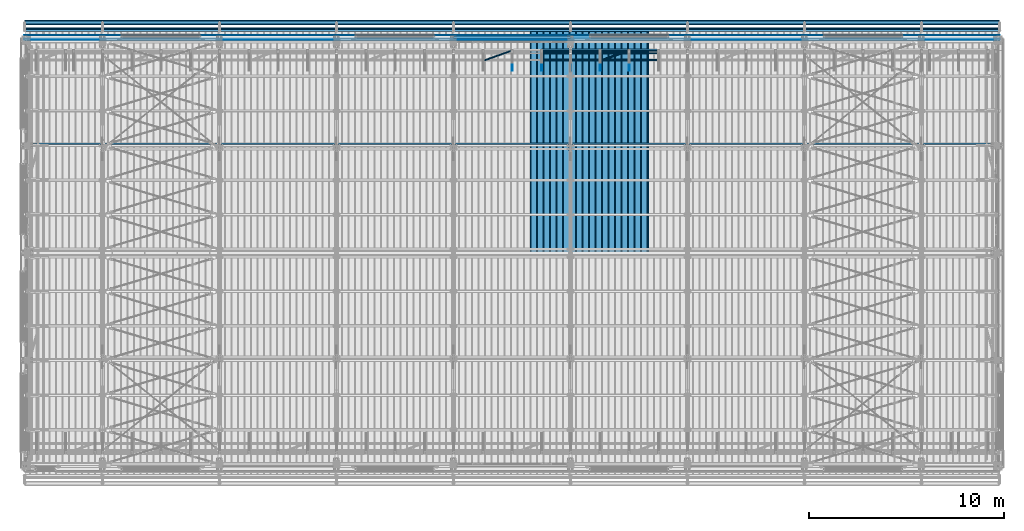
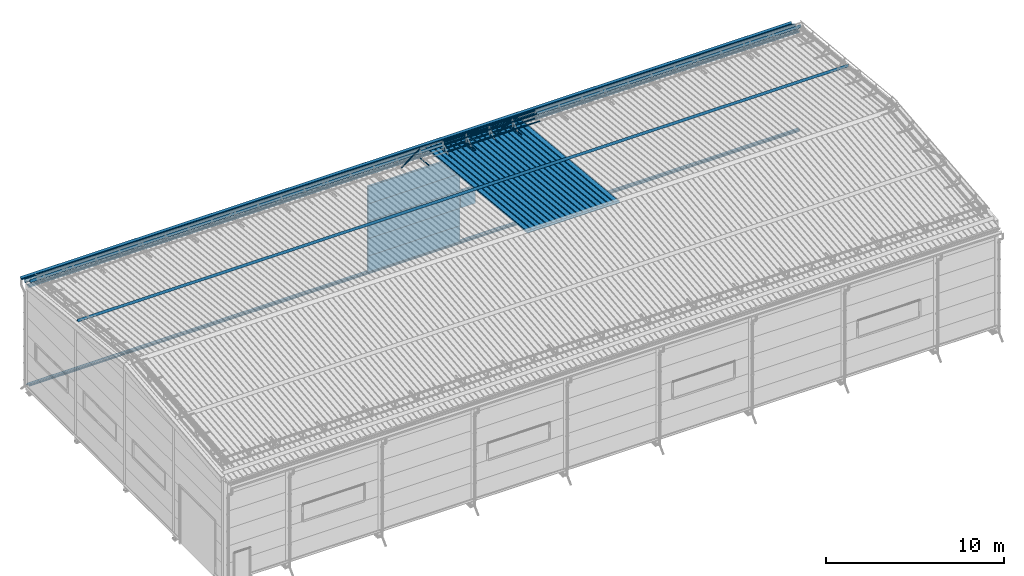
# One storey, part 61 of 709: 32 beams, 32 elements without a shape of their own.
"""IFC4 building model written with IfcOpenShell, lengths in millimetres."""

from ifc_helpers import new_model, si_unit, direction, frame, origin_with_axes, place, context, subcontext, project, spatial, line, indexed_curve, outline, extrude, material, element, aggregate, save


model = new_model("IFC4")

# Units and contexts
model_context = context("Model", 3, precision=0.2, world=origin_with_axes(), true_north=direction((0.0, 1.0)))
body_context = subcontext(model_context, "Body", "Model", "MODEL_VIEW")
ifc_project = project(units=[si_unit("LENGTHUNIT", "METRE", prefix="MILLI"), si_unit("AREAUNIT", "SQUARE_METRE"), si_unit("VOLUMEUNIT", "CUBIC_METRE"), si_unit("MASSUNIT", "GRAM", prefix="KILO"), si_unit("TIMEUNIT", "SECOND"), si_unit("PLANEANGLEUNIT", "RADIAN"), si_unit("SOLIDANGLEUNIT", "STERADIAN"), si_unit("THERMODYNAMICTEMPERATUREUNIT", "DEGREE_CELSIUS"), si_unit("LUMINOUSINTENSITYUNIT", "LUMEN")], contexts=[model_context])

# Site, building, storey
site_placement = place(None, origin_with_axes())
site = spatial("IfcSite", under=ifc_project, at=site_placement, CompositionType="ELEMENT")
building_placement = place(site_placement, origin_with_axes())
building = spatial("IfcBuilding", under=site, at=building_placement, Name="Undefined", CompositionType="ELEMENT")
storey_placement = place(building_placement, origin_with_axes())
storey = spatial("IfcBuildingStorey", under=building, at=storey_placement, Name="Undefined", CompositionType="ELEMENT", Elevation=0.0)

# Assembly, beam
assembly_1_placement = place(storey_placement, frame((31452.44, 11009.10459, 8419.96887), z_axis=(1.0, 0.0, 0.0), x_axis=(0.0, 0.9950371902, -0.099503719)))
assembly_1 = element("IfcElementAssembly", 1, at=assembly_1_placement, inside=storey)
ifc_material_1 = material(Name="Insulation", Category="Insulation")
beam_1_placement = place(assembly_1_placement, origin_with_axes())
beam_1 = element("IfcBeam", 2, at=beam_1_placement, material=ifc_material_1, ObjectType="P-99", context=body_context, shape_type="SolidModel", body=[
    extrude(outline(indexed_curve([(-509.8453, 89.5), (-490.1547, 89.5), (-471.67949, 57.5), (-471.67949, -88.5), (-436.67949, -88.5), (-436.67949, -91.5), (562.55841, -91.5), (562.55841, -89.5), (527.55841, -89.5), (527.55841, 57.5), (510.2379, 88.5), (489.7621, 88.5), (472.44159, 58.5), (196.71923, 58.5), (177.66667, 91.5), (155.66667, 91.5), (136.61411, 58.5), (-136.61411, 58.5), (-155.66667, 91.5), (-177.66667, 91.5), (-196.71923, 58.5), (-469.94744, 58.5), (-489.0, 91.5), (-511.0, 91.5), (-527.16581, 63.5), (-525.43376, 62.5)], segments=[line(1, 2, 3, 4, 5, 6, 7, 8, 9, 10, 11, 12, 13, 14, 15, 16, 17, 18, 19, 20, 21, 22, 23, 24, 25, 26, 1)])), frame((0.0, 0.0, 0.0), z_axis=(-1.0, 0.0, 0.0), x_axis=(0.0, 0.0, 1.0)), (0.0, 0.0, -1.0), 11459.0),
])
aggregate(assembly_1, [beam_1])

assembly_2_placement = place(storey_placement, frame((30452.44, 11009.10459, 8419.96887), z_axis=(1.0, 0.0, 0.0), x_axis=(0.0, 0.9950371902, -0.099503719)))
assembly_2 = element("IfcElementAssembly", 3, at=assembly_2_placement, inside=storey)
beam_2_placement = place(assembly_2_placement, origin_with_axes())
beam_2 = element("IfcBeam", 4, at=beam_2_placement, material=ifc_material_1, ObjectType="P-99", context=body_context, shape_type="SolidModel", body=[
    extrude(outline(indexed_curve([(-509.8453, 89.5), (-490.1547, 89.5), (-471.67949, 57.5), (-471.67949, -88.5), (-436.67949, -88.5), (-436.67949, -91.5), (562.55841, -91.5), (562.55841, -89.5), (527.55841, -89.5), (527.55841, 57.5), (510.2379, 88.5), (489.7621, 88.5), (472.44159, 58.5), (196.71923, 58.5), (177.66667, 91.5), (155.66667, 91.5), (136.61411, 58.5), (-136.61411, 58.5), (-155.66667, 91.5), (-177.66667, 91.5), (-196.71923, 58.5), (-469.94744, 58.5), (-489.0, 91.5), (-511.0, 91.5), (-527.16581, 63.5), (-525.43376, 62.5)], segments=[line(1, 2, 3, 4, 5, 6, 7, 8, 9, 10, 11, 12, 13, 14, 15, 16, 17, 18, 19, 20, 21, 22, 23, 24, 25, 26, 1)])), frame((0.0, 0.0, 0.0), z_axis=(-1.0, 0.0, 0.0), x_axis=(0.0, 0.0, 1.0)), (0.0, 0.0, -1.0), 11459.0),
])
aggregate(assembly_2, [beam_2])

assembly_3_placement = place(storey_placement, frame((29452.44, 11009.10459, 8419.96887), z_axis=(1.0, 0.0, 0.0), x_axis=(0.0, 0.9950371902, -0.099503719)))
assembly_3 = element("IfcElementAssembly", 5, at=assembly_3_placement, inside=storey)
beam_3_placement = place(assembly_3_placement, origin_with_axes())
beam_3 = element("IfcBeam", 6, at=beam_3_placement, material=ifc_material_1, ObjectType="P-99", context=body_context, shape_type="SolidModel", body=[
    extrude(outline(indexed_curve([(-509.8453, 89.5), (-490.1547, 89.5), (-471.67949, 57.5), (-471.67949, -88.5), (-436.67949, -88.5), (-436.67949, -91.5), (562.55841, -91.5), (562.55841, -89.5), (527.55841, -89.5), (527.55841, 57.5), (510.2379, 88.5), (489.7621, 88.5), (472.44159, 58.5), (196.71923, 58.5), (177.66667, 91.5), (155.66667, 91.5), (136.61411, 58.5), (-136.61411, 58.5), (-155.66667, 91.5), (-177.66667, 91.5), (-196.71923, 58.5), (-469.94744, 58.5), (-489.0, 91.5), (-511.0, 91.5), (-527.16581, 63.5), (-525.43376, 62.5)], segments=[line(1, 2, 3, 4, 5, 6, 7, 8, 9, 10, 11, 12, 13, 14, 15, 16, 17, 18, 19, 20, 21, 22, 23, 24, 25, 26, 1)])), frame((0.0, 0.0, 0.0), z_axis=(-1.0, 0.0, 0.0), x_axis=(0.0, 0.0, 1.0)), (0.0, 0.0, -1.0), 11459.0),
])
aggregate(assembly_3, [beam_3])

assembly_4_placement = place(storey_placement, frame((28452.44, 11009.10459, 8419.96887), z_axis=(1.0, 0.0, 0.0), x_axis=(0.0, 0.9950371902, -0.099503719)))
assembly_4 = element("IfcElementAssembly", 7, at=assembly_4_placement, inside=storey)
beam_4_placement = place(assembly_4_placement, origin_with_axes())
beam_4 = element("IfcBeam", 8, at=beam_4_placement, material=ifc_material_1, ObjectType="P-99", context=body_context, shape_type="SolidModel", body=[
    extrude(outline(indexed_curve([(-509.8453, 89.5), (-490.1547, 89.5), (-471.67949, 57.5), (-471.67949, -88.5), (-436.67949, -88.5), (-436.67949, -91.5), (562.55841, -91.5), (562.55841, -89.5), (527.55841, -89.5), (527.55841, 57.5), (510.2379, 88.5), (489.7621, 88.5), (472.44159, 58.5), (196.71923, 58.5), (177.66667, 91.5), (155.66667, 91.5), (136.61411, 58.5), (-136.61411, 58.5), (-155.66667, 91.5), (-177.66667, 91.5), (-196.71923, 58.5), (-469.94744, 58.5), (-489.0, 91.5), (-511.0, 91.5), (-527.16581, 63.5), (-525.43376, 62.5)], segments=[line(1, 2, 3, 4, 5, 6, 7, 8, 9, 10, 11, 12, 13, 14, 15, 16, 17, 18, 19, 20, 21, 22, 23, 24, 25, 26, 1)])), frame((0.0, 0.0, 0.0), z_axis=(-1.0, 0.0, 0.0), x_axis=(0.0, 0.0, 1.0)), (0.0, 0.0, -1.0), 11459.0),
])
aggregate(assembly_4, [beam_4])

assembly_5_placement = place(storey_placement, frame((27452.44, 11009.10459, 8419.96887), z_axis=(1.0, 0.0, 0.0), x_axis=(0.0, 0.9950371902, -0.099503719)))
assembly_5 = element("IfcElementAssembly", 9, at=assembly_5_placement, inside=storey)
beam_5_placement = place(assembly_5_placement, origin_with_axes())
beam_5 = element("IfcBeam", 10, at=beam_5_placement, material=ifc_material_1, ObjectType="P-99", context=body_context, shape_type="SolidModel", body=[
    extrude(outline(indexed_curve([(-509.8453, 89.5), (-490.1547, 89.5), (-471.67949, 57.5), (-471.67949, -88.5), (-436.67949, -88.5), (-436.67949, -91.5), (562.55841, -91.5), (562.55841, -89.5), (527.55841, -89.5), (527.55841, 57.5), (510.2379, 88.5), (489.7621, 88.5), (472.44159, 58.5), (196.71923, 58.5), (177.66667, 91.5), (155.66667, 91.5), (136.61411, 58.5), (-136.61411, 58.5), (-155.66667, 91.5), (-177.66667, 91.5), (-196.71923, 58.5), (-469.94744, 58.5), (-489.0, 91.5), (-511.0, 91.5), (-527.16581, 63.5), (-525.43376, 62.5)], segments=[line(1, 2, 3, 4, 5, 6, 7, 8, 9, 10, 11, 12, 13, 14, 15, 16, 17, 18, 19, 20, 21, 22, 23, 24, 25, 26, 1)])), frame((0.0, 0.0, 0.0), z_axis=(-1.0, 0.0, 0.0), x_axis=(0.0, 0.0, 1.0)), (0.0, 0.0, -1.0), 11459.0),
])
aggregate(assembly_5, [beam_5])

assembly_6_placement = place(storey_placement, frame((26452.44, 11009.10459, 8419.96887), z_axis=(1.0, 0.0, 0.0), x_axis=(0.0, 0.9950371902, -0.099503719)))
assembly_6 = element("IfcElementAssembly", 11, at=assembly_6_placement, inside=storey)
beam_6_placement = place(assembly_6_placement, origin_with_axes())
beam_6 = element("IfcBeam", 12, at=beam_6_placement, material=ifc_material_1, ObjectType="P-99", context=body_context, shape_type="SolidModel", body=[
    extrude(outline(indexed_curve([(-509.8453, 89.5), (-490.1547, 89.5), (-471.67949, 57.5), (-471.67949, -88.5), (-436.67949, -88.5), (-436.67949, -91.5), (562.55841, -91.5), (562.55841, -89.5), (527.55841, -89.5), (527.55841, 57.5), (510.2379, 88.5), (489.7621, 88.5), (472.44159, 58.5), (196.71923, 58.5), (177.66667, 91.5), (155.66667, 91.5), (136.61411, 58.5), (-136.61411, 58.5), (-155.66667, 91.5), (-177.66667, 91.5), (-196.71923, 58.5), (-469.94744, 58.5), (-489.0, 91.5), (-511.0, 91.5), (-527.16581, 63.5), (-525.43376, 62.5)], segments=[line(1, 2, 3, 4, 5, 6, 7, 8, 9, 10, 11, 12, 13, 14, 15, 16, 17, 18, 19, 20, 21, 22, 23, 24, 25, 26, 1)])), frame((0.0, 0.0, 0.0), z_axis=(-1.0, 0.0, 0.0), x_axis=(0.0, 0.0, 1.0)), (0.0, 0.0, -1.0), 11459.0),
])
aggregate(assembly_6, [beam_6])

assembly_7_placement = place(storey_placement, frame((20.0, 22503.78213, 7203.66945), z_axis=(0.0, 0.099503719, 0.9950371902), x_axis=(1.0, 0.0, 0.0)))
assembly_7 = element("IfcElementAssembly", 13, at=assembly_7_placement, inside=storey)
ifc_material_2 = material(Name="Steel_Undefined", Category="STEEL")
beam_7_placement = place(assembly_7_placement, origin_with_axes())
beam_7 = element("IfcBeam", 14, at=beam_7_placement, material=ifc_material_2, context=body_context, shape_type="SolidModel", body=[
    extrude(outline(indexed_curve([(-100.75, -24.25), (-100.75, -124.25), (-100.0, -124.25), (-100.0, -25.0), (100.0, -25.0), (100.0, 25.0), (71.32118, 65.9576), (70.70681, 65.52742), (99.25, 24.76353), (99.25, -24.25)], segments=[line(1, 2, 3, 4, 5, 6, 7, 8, 9, 10, 1)])), frame((0.0, 0.0, 0.0), z_axis=(-1.0, 0.0, 0.0), x_axis=(0.0, 0.0, 1.0)), (0.0, 0.0, -1.0), 49995.0),
])
aggregate(assembly_7, [beam_7])

assembly_8_placement = place(storey_placement, frame((20.0, 21874.57939, 7541.95631), z_axis=(0.0, 0.099503719, 0.9950371902), x_axis=(1.0, 0.0, 0.0)))
assembly_8 = element("IfcElementAssembly", 15, at=assembly_8_placement, inside=storey)
beam_8_placement = place(assembly_8_placement, origin_with_axes())
beam_8 = element("IfcBeam", 16, at=beam_8_placement, material=ifc_material_2, context=body_context, shape_type="SolidModel", body=[
    extrude(outline(indexed_curve([(-100.0, -1.0), (100.0, -1.0), (-99.18584, 114.0), (-100.18584, 112.26795), (92.5359, 1.0), (-100.0, 1.0)], segments=[line(1, 2, 3, 4, 5, 6, 1)])), frame((0.0, 0.0, 0.0), z_axis=(-1.0, 0.0, 0.0), x_axis=(0.0, 0.0, 1.0)), (0.0, 0.0, -1.0), 49995.0),
])
aggregate(assembly_8, [beam_8])

assembly_9_placement = place(storey_placement, frame((20.0, 16544.48013, 8074.96624), z_axis=(0.0, 0.099503719, 0.9950371902), x_axis=(1.0, 0.0, 0.0)))
assembly_9 = element("IfcElementAssembly", 17, at=assembly_9_placement, inside=storey)
beam_9_placement = place(assembly_9_placement, origin_with_axes())
beam_9 = element("IfcBeam", 18, at=beam_9_placement, material=ifc_material_2, context=body_context, shape_type="SolidModel", body=[
    extrude(outline(indexed_curve([(-100.0, -1.0), (100.0, -1.0), (-99.18584, 114.0), (-100.18584, 112.26795), (92.5359, 1.0), (-100.0, 1.0)], segments=[line(1, 2, 3, 4, 5, 6, 1)])), frame((0.0, 0.0, 0.0), z_axis=(-1.0, 0.0, 0.0), x_axis=(0.0, 0.0, 1.0)), (0.0, 0.0, -1.0), 49995.0),
])
aggregate(assembly_9, [beam_9])

assembly_10_placement = place(storey_placement, frame((31015.0, 21349.29926, 7565.33969), z_axis=(0.0, 0.099503719, 0.9950371902), x_axis=(0.0, -0.9950371902, 0.099503719)))
assembly_10 = element("IfcElementAssembly", 19, at=assembly_10_placement, inside=storey)
beam_10_placement = place(assembly_10_placement, origin_with_axes())
beam_10 = element("IfcBeam", 20, at=beam_10_placement, material=ifc_material_2, ObjectType="601", context=body_context, shape_type="SolidModel", body=[
    extrude(outline(indexed_curve([(-20.0, -25.0), (20.0, -25.0), (20.0, -22.5), (-17.5, -22.5), (-17.5, 22.5), (20.0, 22.5), (20.0, 25.0), (-20.0, 25.0)], segments=[line(1, 2, 3, 4, 5, 6, 7, 8, 1)])), frame((0.0, 0.0, 0.0), z_axis=(-1.0, 0.0, 0.0), x_axis=(0.0, 0.0, 1.0)), (0.0, 0.0, -1.0), 1000.0),
])
aggregate(assembly_10, [beam_10])

assembly_11_placement = place(storey_placement, frame((29515.0, 21349.29926, 7565.33969), z_axis=(0.0, 0.099503719, 0.9950371902), x_axis=(0.0, -0.9950371902, 0.099503719)))
assembly_11 = element("IfcElementAssembly", 21, at=assembly_11_placement, inside=storey)
beam_11_placement = place(assembly_11_placement, origin_with_axes())
beam_11 = element("IfcBeam", 22, at=beam_11_placement, material=ifc_material_2, ObjectType="601", context=body_context, shape_type="SolidModel", body=[
    extrude(outline(indexed_curve([(-20.0, -25.0), (20.0, -25.0), (20.0, -22.5), (-17.5, -22.5), (-17.5, 22.5), (20.0, 22.5), (20.0, 25.0), (-20.0, 25.0)], segments=[line(1, 2, 3, 4, 5, 6, 7, 8, 1)])), frame((0.0, 0.0, 0.0), z_axis=(-1.0, 0.0, 0.0), x_axis=(0.0, 0.0, 1.0)), (0.0, 0.0, -1.0), 1000.0),
])
aggregate(assembly_11, [beam_11])

assembly_12_placement = place(storey_placement, frame((28015.0, 21349.29926, 7565.33969), z_axis=(0.0, 0.099503719, 0.9950371902), x_axis=(0.0, -0.9950371902, 0.099503719)))
assembly_12 = element("IfcElementAssembly", 23, at=assembly_12_placement, inside=storey)
beam_12_placement = place(assembly_12_placement, origin_with_axes())
beam_12 = element("IfcBeam", 24, at=beam_12_placement, material=ifc_material_2, ObjectType="601", context=body_context, shape_type="SolidModel", body=[
    extrude(outline(indexed_curve([(-20.0, -25.0), (20.0, -25.0), (20.0, -22.5), (-17.5, -22.5), (-17.5, 22.5), (20.0, 22.5), (20.0, 25.0), (-20.0, 25.0)], segments=[line(1, 2, 3, 4, 5, 6, 7, 8, 1)])), frame((0.0, 0.0, 0.0), z_axis=(-1.0, 0.0, 0.0), x_axis=(0.0, 0.0, 1.0)), (0.0, 0.0, -1.0), 1000.0),
])
aggregate(assembly_12, [beam_12])

assembly_13_placement = place(storey_placement, frame((32515.0, 21426.91216, 8140.47118), z_axis=(0.0, 0.9950371902, -0.099503719), x_axis=(-1.0, 0.0, 0.0)))
assembly_13 = element("IfcElementAssembly", 25, at=assembly_13_placement, inside=storey)
beam_13_placement = place(assembly_13_placement, origin_with_axes())
beam_13 = element("IfcBeam", 26, at=beam_13_placement, material=ifc_material_2, ObjectType="606", context=body_context, shape_type="SolidModel", body=[
    extrude(outline(indexed_curve([(-20.0, -25.0), (20.0, -25.0), (20.0, -22.5), (-17.5, -22.5), (-17.5, 22.5), (20.0, 22.5), (20.0, 25.0), (-20.0, 25.0)], segments=[line(1, 2, 3, 4, 5, 6, 7, 8, 1)])), frame((0.0, 0.0, 0.0), z_axis=(-1.0, 0.0, 0.0), x_axis=(0.0, 0.0, 1.0)), (0.0, 0.0, -1.0), 6000.0),
])
aggregate(assembly_13, [beam_13])

assembly_14_placement = place(storey_placement, frame((32515.0, 21377.1603, 7642.95259), z_axis=(0.0, 0.9950371902, -0.099503719), x_axis=(-1.0, 0.0, 0.0)))
assembly_14 = element("IfcElementAssembly", 27, at=assembly_14_placement, inside=storey)
beam_14_placement = place(assembly_14_placement, origin_with_axes())
beam_14 = element("IfcBeam", 28, at=beam_14_placement, material=ifc_material_2, ObjectType="606", context=body_context, shape_type="SolidModel", body=[
    extrude(outline(indexed_curve([(-20.0, -25.0), (20.0, -25.0), (20.0, -22.5), (-17.5, -22.5), (-17.5, 22.5), (20.0, 22.5), (20.0, 25.0), (-20.0, 25.0)], segments=[line(1, 2, 3, 4, 5, 6, 7, 8, 1)])), frame((0.0, 0.0, 0.0), z_axis=(-1.0, 0.0, 0.0), x_axis=(0.0, 0.0, 1.0)), (0.0, 0.0, -1.0), 6000.0),
])
aggregate(assembly_14, [beam_14])

assembly_15_placement = place(storey_placement, frame((32515.0, 21239.5552, 8031.29285), z_axis=(0.0, -0.6332377902, 0.7739572992), x_axis=(-1.0, 0.0, 0.0)))
assembly_15 = element("IfcElementAssembly", 29, at=assembly_15_placement, inside=storey)
beam_15_placement = place(assembly_15_placement, origin_with_axes())
beam_15 = element("IfcBeam", 30, at=beam_15_placement, material=ifc_material_2, ObjectType="606", context=body_context, shape_type="SolidModel", body=[
    extrude(outline(indexed_curve([(-20.0, -25.0), (20.0, -25.0), (20.0, -22.5), (-17.5, -22.5), (-17.5, 22.5), (20.0, 22.5), (20.0, 25.0), (-20.0, 25.0)], segments=[line(1, 2, 3, 4, 5, 6, 7, 8, 1)])), frame((0.0, 0.0, 0.0), z_axis=(-1.0, 0.0, 0.0), x_axis=(0.0, 0.0, 1.0)), (0.0, 0.0, -1.0), 6000.0),
])
aggregate(assembly_15, [beam_15])

assembly_16_placement = place(storey_placement, frame((32515.0, 20892.41357, 7747.26788), z_axis=(0.0, -0.6332377902, 0.7739572992), x_axis=(-1.0, 0.0, 0.0)))
assembly_16 = element("IfcElementAssembly", 31, at=assembly_16_placement, inside=storey)
beam_16_placement = place(assembly_16_placement, origin_with_axes())
beam_16 = element("IfcBeam", 32, at=beam_16_placement, material=ifc_material_2, ObjectType="606", context=body_context, shape_type="SolidModel", body=[
    extrude(outline(indexed_curve([(-20.0, -25.0), (20.0, -25.0), (20.0, -22.5), (-17.5, -22.5), (-17.5, 22.5), (20.0, 22.5), (20.0, 25.0), (-20.0, 25.0)], segments=[line(1, 2, 3, 4, 5, 6, 7, 8, 1)])), frame((0.0, 0.0, 0.0), z_axis=(-1.0, 0.0, 0.0), x_axis=(0.0, 0.0, 1.0)), (0.0, 0.0, -1.0), 6000.0),
])
aggregate(assembly_16, [beam_16])

assembly_17_placement = place(storey_placement, frame((31015.0, 21394.34666, 8157.9404), z_axis=(0.0, -0.6332377902, 0.7739572992), x_axis=(-0.9061831398, -0.3272952929, -0.2677870579)))
assembly_17 = element("IfcElementAssembly", 33, at=assembly_17_placement, inside=storey)
beam_17_placement = place(assembly_17_placement, origin_with_axes())
beam_17 = element("IfcBeam", 34, at=beam_17_placement, material=ifc_material_2, ObjectType="605", context=body_context, shape_type="SolidModel", body=[
    extrude(outline(indexed_curve([(-20.0, -25.0), (20.0, -25.0), (20.0, -22.5), (-17.5, -22.5), (-17.5, 22.5), (20.0, 22.5), (20.0, 25.0), (-20.0, 25.0)], segments=[line(1, 2, 3, 4, 5, 6, 7, 8, 1)])), frame((0.0, 0.0, 0.0), z_axis=(-1.0, 0.0, 0.0), x_axis=(0.0, 0.0, 1.0)), (0.0, 0.0, -1.0), 1655.29454),
])
aggregate(assembly_17, [beam_17])

assembly_18_placement = place(storey_placement, frame((26515.0, 21349.29926, 7565.33969), z_axis=(0.0, 0.099503719, 0.9950371902), x_axis=(0.0, -0.9950371902, 0.099503719)))
assembly_18 = element("IfcElementAssembly", 35, at=assembly_18_placement, inside=storey)
beam_18_placement = place(assembly_18_placement, origin_with_axes())
beam_18 = element("IfcBeam", 36, at=beam_18_placement, material=ifc_material_2, ObjectType="601", context=body_context, shape_type="SolidModel", body=[
    extrude(outline(indexed_curve([(-20.0, -25.0), (20.0, -25.0), (20.0, -22.5), (-17.5, -22.5), (-17.5, 22.5), (20.0, 22.5), (20.0, 25.0), (-20.0, 25.0)], segments=[line(1, 2, 3, 4, 5, 6, 7, 8, 1)])), frame((0.0, 0.0, 0.0), z_axis=(-1.0, 0.0, 0.0), x_axis=(0.0, 0.0, 1.0)), (0.0, 0.0, -1.0), 1000.0),
])
aggregate(assembly_18, [beam_18])

assembly_19_placement = place(storey_placement, frame((25015.0, 21349.29926, 7565.33969), z_axis=(0.0, 0.099503719, 0.9950371902), x_axis=(0.0, -0.9950371902, 0.099503719)))
assembly_19 = element("IfcElementAssembly", 37, at=assembly_19_placement, inside=storey)
beam_19_placement = place(assembly_19_placement, origin_with_axes())
beam_19 = element("IfcBeam", 38, at=beam_19_placement, material=ifc_material_2, ObjectType="601", context=body_context, shape_type="SolidModel", body=[
    extrude(outline(indexed_curve([(-20.0, -25.0), (20.0, -25.0), (20.0, -22.5), (-17.5, -22.5), (-17.5, 22.5), (20.0, 22.5), (20.0, 25.0), (-20.0, 25.0)], segments=[line(1, 2, 3, 4, 5, 6, 7, 8, 1)])), frame((0.0, 0.0, 0.0), z_axis=(-1.0, 0.0, 0.0), x_axis=(0.0, 0.0, 1.0)), (0.0, 0.0, -1.0), 1000.0),
])
aggregate(assembly_19, [beam_19])

assembly_20_placement = place(storey_placement, frame((25015.0, 21394.34666, 8157.9404), z_axis=(0.0, -0.6332377902, 0.7739572992), x_axis=(-0.9061831398, -0.3272952929, -0.2677870579)))
assembly_20 = element("IfcElementAssembly", 39, at=assembly_20_placement, inside=storey)
beam_20_placement = place(assembly_20_placement, origin_with_axes())
beam_20 = element("IfcBeam", 40, at=beam_20_placement, material=ifc_material_2, ObjectType="605", context=body_context, shape_type="SolidModel", body=[
    extrude(outline(indexed_curve([(-20.0, -25.0), (20.0, -25.0), (20.0, -22.5), (-17.5, -22.5), (-17.5, 22.5), (20.0, 22.5), (20.0, 25.0), (-20.0, 25.0)], segments=[line(1, 2, 3, 4, 5, 6, 7, 8, 1)])), frame((0.0, 0.0, 0.0), z_axis=(-1.0, 0.0, 0.0), x_axis=(0.0, 0.0, 1.0)), (0.0, 0.0, -1.0), 1655.29454),
])
aggregate(assembly_20, [beam_20])

assembly_21_placement = place(storey_placement, frame((22010.0, 22060.0, 895.0), z_axis=(0.0, 0.0, -1.0), x_axis=(1.0, 0.0, 0.0)))
assembly_21 = element("IfcElementAssembly", 41, at=assembly_21_placement, inside=storey)
beam_21_placement = place(assembly_21_placement, origin_with_axes())
beam_21 = element("IfcBeam", 42, at=beam_21_placement, material=ifc_material_1, ObjectType="P-107", context=body_context, shape_type="SolidModel", body=[
    extrude(outline(indexed_curve([(-595.0, -60.0), (595.0, -60.0), (595.0, 60.0), (-595.0, 60.0)], segments=[line(1, 2, 3, 4, 1)])), frame((0.0, 0.0, 0.0), z_axis=(-1.0, 0.0, 0.0), x_axis=(0.0, 0.0, 1.0)), (0.0, 0.0, -1.0), 5980.0),
])
aggregate(assembly_21, [beam_21])

assembly_22_placement = place(storey_placement, frame((22010.0, 22060.0, 2085.0), z_axis=(0.0, 0.0, -1.0), x_axis=(1.0, 0.0, 0.0)))
assembly_22 = element("IfcElementAssembly", 43, at=assembly_22_placement, inside=storey)
beam_22_placement = place(assembly_22_placement, origin_with_axes())
beam_22 = element("IfcBeam", 44, at=beam_22_placement, material=ifc_material_1, ObjectType="P-107", context=body_context, shape_type="SolidModel", body=[
    extrude(outline(indexed_curve([(-595.0, -60.0), (595.0, -60.0), (595.0, 60.0), (-595.0, 60.0)], segments=[line(1, 2, 3, 4, 1)])), frame((0.0, 0.0, 0.0), z_axis=(-1.0, 0.0, 0.0), x_axis=(0.0, 0.0, 1.0)), (0.0, 0.0, -1.0), 5980.0),
])
aggregate(assembly_22, [beam_22])

assembly_23_placement = place(storey_placement, frame((22010.0, 22060.0, 3275.0), z_axis=(0.0, 0.0, -1.0), x_axis=(1.0, 0.0, 0.0)))
assembly_23 = element("IfcElementAssembly", 45, at=assembly_23_placement, inside=storey)
beam_23_placement = place(assembly_23_placement, origin_with_axes())
beam_23 = element("IfcBeam", 46, at=beam_23_placement, material=ifc_material_1, ObjectType="P-107", context=body_context, shape_type="SolidModel", body=[
    extrude(outline(indexed_curve([(-595.0, -60.0), (595.0, -60.0), (595.0, 60.0), (-595.0, 60.0)], segments=[line(1, 2, 3, 4, 1)])), frame((0.0, 0.0, 0.0), z_axis=(-1.0, 0.0, 0.0), x_axis=(0.0, 0.0, 1.0)), (0.0, 0.0, -1.0), 5980.0),
])
aggregate(assembly_23, [beam_23])

assembly_24_placement = place(storey_placement, frame((22010.0, 22060.0, 4465.0), z_axis=(0.0, 0.0, -1.0), x_axis=(1.0, 0.0, 0.0)))
assembly_24 = element("IfcElementAssembly", 47, at=assembly_24_placement, inside=storey)
beam_24_placement = place(assembly_24_placement, origin_with_axes())
beam_24 = element("IfcBeam", 48, at=beam_24_placement, material=ifc_material_1, ObjectType="P-107", context=body_context, shape_type="SolidModel", body=[
    extrude(outline(indexed_curve([(-595.0, -60.0), (595.0, -60.0), (595.0, 60.0), (-595.0, 60.0)], segments=[line(1, 2, 3, 4, 1)])), frame((0.0, 0.0, 0.0), z_axis=(-1.0, 0.0, 0.0), x_axis=(0.0, 0.0, 1.0)), (0.0, 0.0, -1.0), 5980.0),
])
aggregate(assembly_24, [beam_24])

assembly_25_placement = place(storey_placement, frame((22010.0, 22060.0, 5655.0), z_axis=(0.0, 0.0, -1.0), x_axis=(1.0, 0.0, 0.0)))
assembly_25 = element("IfcElementAssembly", 49, at=assembly_25_placement, inside=storey)
beam_25_placement = place(assembly_25_placement, origin_with_axes())
beam_25 = element("IfcBeam", 50, at=beam_25_placement, material=ifc_material_1, ObjectType="P-107", context=body_context, shape_type="SolidModel", body=[
    extrude(outline(indexed_curve([(-595.0, -60.0), (595.0, -60.0), (595.0, 60.0), (-595.0, 60.0)], segments=[line(1, 2, 3, 4, 1)])), frame((0.0, 0.0, 0.0), z_axis=(-1.0, 0.0, 0.0), x_axis=(0.0, 0.0, 1.0)), (0.0, 0.0, -1.0), 5980.0),
])
aggregate(assembly_25, [beam_25])

assembly_26_placement = place(storey_placement, frame((28010.0, 22060.0, 3275.0), z_axis=(0.0, 0.0, -1.0), x_axis=(1.0, 0.0, 0.0)))
assembly_26 = element("IfcElementAssembly", 51, at=assembly_26_placement, inside=storey)
beam_26_placement = place(assembly_26_placement, origin_with_axes())
beam_26 = element("IfcBeam", 52, at=beam_26_placement, material=ifc_material_1, ObjectType="P-110", context=body_context, shape_type="SolidModel", body=[
    extrude(outline(indexed_curve([(-595.0, -60.0), (595.0, -60.0), (595.0, 60.0), (-595.0, 60.0)], segments=[line(1, 2, 3, 4, 1)])), frame((0.0, 0.0, 0.0), z_axis=(-1.0, 0.0, 0.0), x_axis=(0.0, 0.0, 1.0)), (0.0, 0.0, -1.0), 990.0),
])
aggregate(assembly_26, [beam_26])

assembly_27_placement = place(storey_placement, frame((0.0, 22170.375, 370.0), z_axis=(0.0, -1.0, 0.0), x_axis=(1.0, 0.0, 0.0)))
assembly_27 = element("IfcElementAssembly", 53, at=assembly_27_placement, inside=storey)
beam_27_placement = place(assembly_27_placement, origin_with_axes())
beam_27 = element("IfcBeam", 54, at=beam_27_placement, material=ifc_material_2, context=body_context, shape_type="SolidModel", body=[
    extrude(outline(indexed_curve([(0.375, -20.0), (0.375, 19.25), (0.495, 19.25), (0.495, 5.0), (1.245, 5.0), (1.245, 20.0), (-0.375, 20.0), (-0.375, -19.68934), (-59.625, -78.93934), (-59.625, -118.93934), (-52.125, -105.94896), (-52.77452, -105.57396), (-58.875, -116.1403), (-58.875, -79.25)], segments=[line(1, 2, 3, 4, 5, 6, 7, 8, 9, 10, 11, 12, 13, 14, 1)])), frame((0.0, 0.0, 0.0), z_axis=(-1.0, 0.0, 0.0), x_axis=(0.0, 0.0, 1.0)), (0.0, 0.0, -1.0), 50000.0),
])
aggregate(assembly_27, [beam_27])

assembly_28_placement = place(storey_placement, frame((50000.0, 22155.0, 350.0), z_axis=(0.0, 0.0, -1.0), x_axis=(-1.0, 0.0, 0.0)))
assembly_28 = element("IfcElementAssembly", 55, at=assembly_28_placement, inside=storey)
beam_28_placement = place(assembly_28_placement, origin_with_axes())
beam_28 = element("IfcBeam", 56, at=beam_28_placement, material=ifc_material_2, context=body_context, shape_type="SolidModel", body=[
    extrude(outline(indexed_curve([(-35.0, -1.0), (35.0, -1.0), (60.98076, 14.0), (59.98076, 15.73205), (34.4641, 1.0), (-35.0, 1.0)], segments=[line(1, 2, 3, 4, 5, 6, 1)])), frame((0.0, 0.0, 0.0), z_axis=(-1.0, 0.0, 0.0), x_axis=(0.0, 0.0, 1.0)), (0.0, 0.0, -1.0), 50000.0),
])
aggregate(assembly_28, [beam_28])

assembly_29_placement = place(storey_placement, frame((0.0, 21985.0, 350.0), z_axis=(0.0, 0.0, -1.0), x_axis=(1.0, 0.0, 0.0)))
assembly_29 = element("IfcElementAssembly", 57, at=assembly_29_placement, inside=storey)
beam_29_placement = place(assembly_29_placement, origin_with_axes())
beam_29 = element("IfcBeam", 58, at=beam_29_placement, material=ifc_material_2, context=body_context, shape_type="SolidModel", body=[
    extrude(outline(indexed_curve([(-45.0, -1.0), (45.0, -1.0), (45.0, 49.0), (43.0, 49.0), (43.0, 1.0), (-45.0, 1.0)], segments=[line(1, 2, 3, 4, 5, 6, 1)])), frame((0.0, 0.0, 0.0), z_axis=(-1.0, 0.0, 0.0), x_axis=(0.0, 0.0, 1.0)), (0.0, 0.0, -1.0), 50000.0),
])
aggregate(assembly_29, [beam_29])

assembly_30_placement = place(storey_placement, frame((50000.0, 21990.0, 7096.92297), z_axis=(0.0, 0.0, 1.0), x_axis=(-1.0, 0.0, 0.0)))
assembly_30 = element("IfcElementAssembly", 59, at=assembly_30_placement, inside=storey)
beam_30_placement = place(assembly_30_placement, origin_with_axes())
beam_30 = element("IfcBeam", 60, at=beam_30_placement, material=ifc_material_2, context=body_context, shape_type="SolidModel", body=[
    extrude(outline(indexed_curve([(-67.5, -1.0), (67.5, -1.0), (76.18241, 48.24039), (74.21279, 48.58768), (65.8218, 1.0), (-67.5, 1.0)], segments=[line(1, 2, 3, 4, 5, 6, 1)])), frame((0.0, 0.0, 0.0), z_axis=(-1.0, 0.0, 0.0), x_axis=(0.0, 0.0, 1.0)), (0.0, 0.0, -1.0), 50000.0),
])
aggregate(assembly_30, [beam_30])

assembly_31_placement = place(storey_placement, frame((0.0, 22130.0, 7096.92297), z_axis=(0.0, 0.0, 1.0), x_axis=(1.0, 0.0, 0.0)))
assembly_31 = element("IfcElementAssembly", 61, at=assembly_31_placement, inside=storey)
beam_31_placement = place(assembly_31_placement, origin_with_axes())
beam_31 = element("IfcBeam", 62, at=beam_31_placement, material=ifc_material_2, context=body_context, shape_type="SolidModel", body=[
    extrude(outline(indexed_curve([(-50.0, -1.0), (50.0, -1.0), (37.81307, 98.25462), (35.82797, 98.01088), (47.73941, 1.0), (-50.0, 1.0)], segments=[line(1, 2, 3, 4, 5, 6, 1)])), frame((0.0, 0.0, 0.0), z_axis=(-1.0, 0.0, 0.0), x_axis=(0.0, 0.0, 1.0)), (0.0, 0.0, -1.0), 50000.0),
])
aggregate(assembly_31, [beam_31])

assembly_32_placement = place(storey_placement, frame((0.0, 22820.0, 7096.92297), z_axis=(0.0, -1.0, 0.0), x_axis=(1.0, 0.0, 0.0)))
assembly_32 = element("IfcElementAssembly", 63, at=assembly_32_placement, inside=storey)
beam_32_placement = place(assembly_32_placement, origin_with_axes())
beam_32 = element("IfcBeam", 64, at=beam_32_placement, material=ifc_material_2, context=body_context, shape_type="SolidModel", body=[
    extrude(outline(indexed_curve([(-70.0, -1.0), (70.0, -1.0), (129.16656, 125.88309), (127.35394, 126.72833), (68.72586, 1.0), (-68.72586, 1.0), (-127.35394, 126.72833), (-129.16656, 125.88309)], segments=[line(1, 2, 3, 4, 5, 6, 7, 8, 1)])), frame((0.0, 0.0, 0.0), z_axis=(-1.0, 0.0, 0.0), x_axis=(0.0, 0.0, 1.0)), (0.0, 0.0, -1.0), 50000.0),
])
aggregate(assembly_32, [beam_32])

save(model, "model.ifc")
